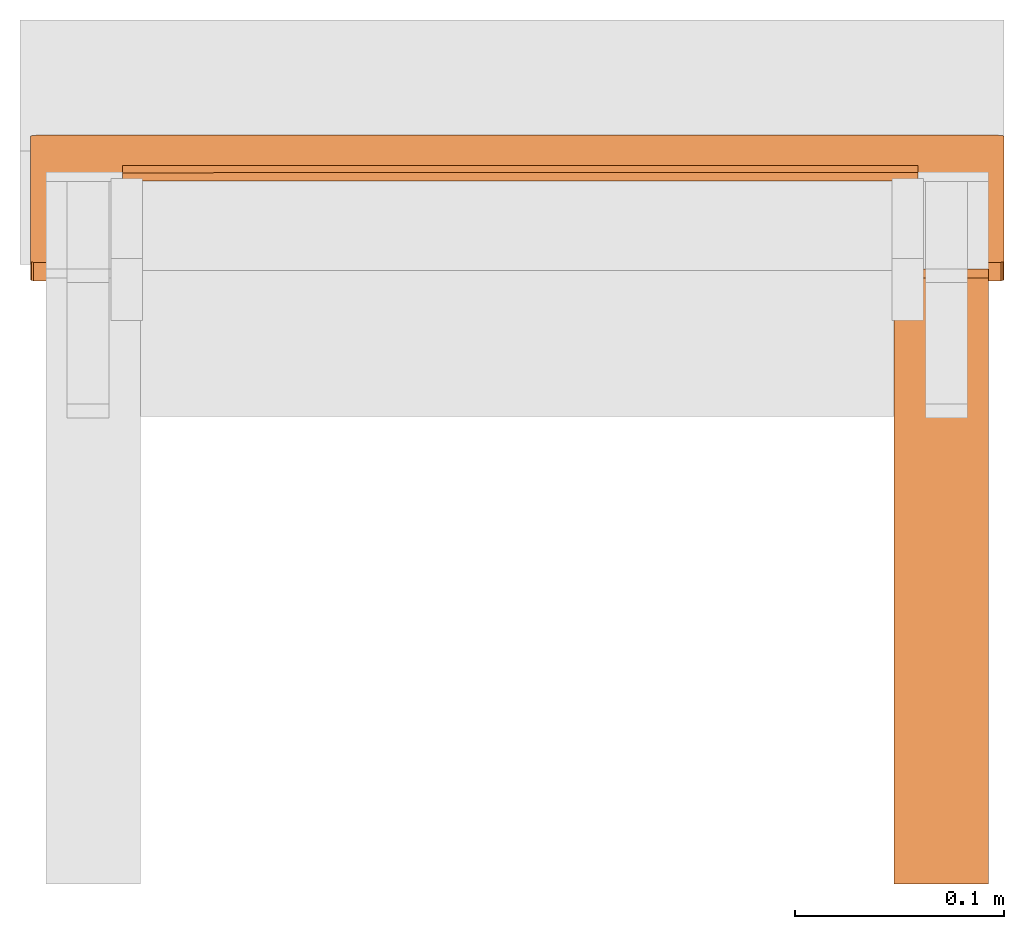
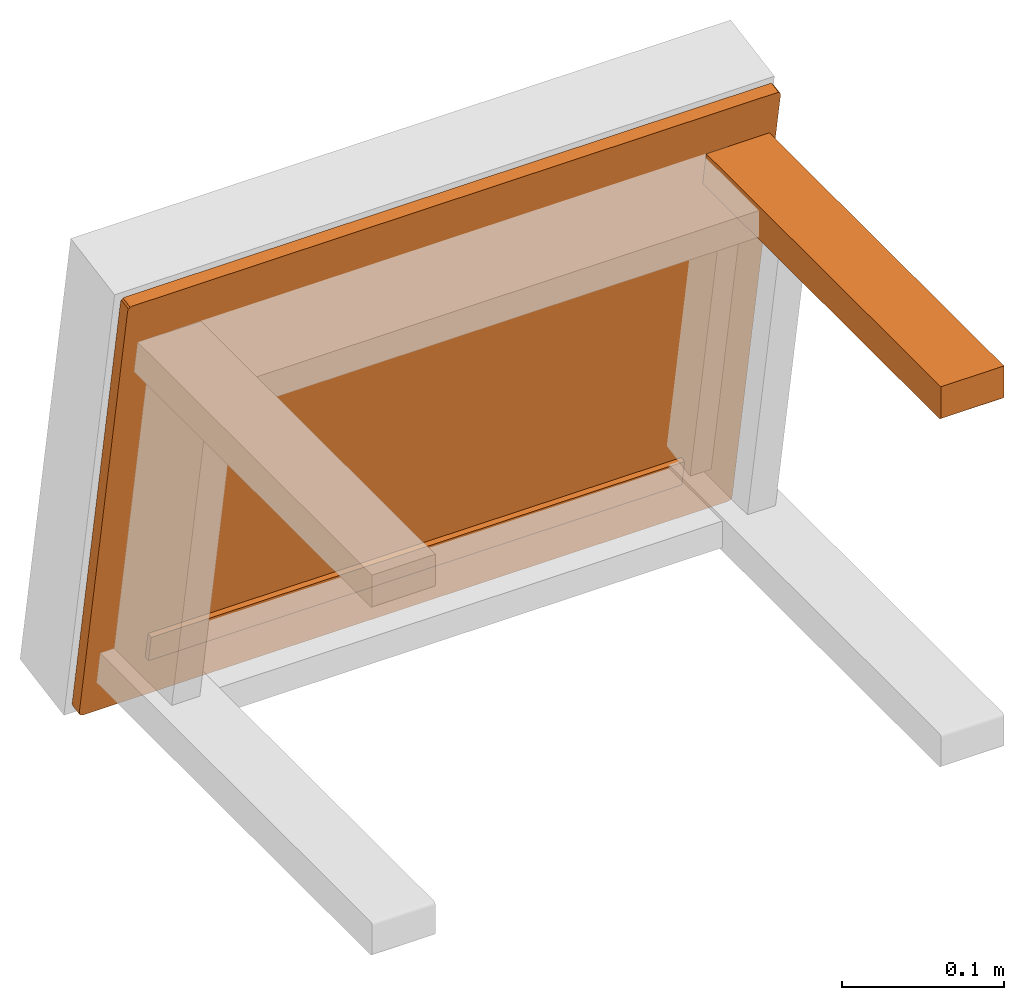
# One storey, part 3 of 5: 3 proxies, 1 element without a shape of its own.
"""IFC2X3 building model written with IfcOpenShell, lengths in metres."""

from ifc_helpers import new_model, si_unit, direction, origin_with_axes, place, context, project, spatial, faceted_brep, source, transform, mapped, element, aggregate, save


model = new_model("IFC2X3")

# Units and contexts
model_context = context("Model", 3, precision=1e-06, world=origin_with_axes(), true_north=direction((0.0, 1.0, 0.0)))
ifc_project = project(units=[si_unit("LENGTHUNIT", "METRE"), si_unit("AREAUNIT", "SQUARE_METRE"), si_unit("VOLUMEUNIT", "CUBIC_METRE")], contexts=[model_context])

# Site, building, storey
site_placement = place(None, origin_with_axes())
site = spatial("IfcSite", under=ifc_project, at=site_placement, CompositionType="ELEMENT")
building_placement = place(site_placement, origin_with_axes())
building = spatial("IfcBuilding", under=site, at=building_placement, Name="Default Building", CompositionType="ELEMENT")
storey_placement = place(building_placement, origin_with_axes())
storey = spatial("IfcBuildingStorey", under=building, at=storey_placement, Name="Default Storey", CompositionType="ELEMENT", Elevation=0.0)

# Assembly, proxies
assembly_placement = place(storey_placement, origin_with_axes())
assembly = element("IfcElementAssembly", 1, at=assembly_placement, inside=storey, Name="Pan H-68-037-A-REV reduced", ObjectType="Pan H-68-037-A-REV reduced", AssemblyPlace="NOTDEFINED", PredefinedType="NOTDEFINED")
shared_shape_1 = source(origin_with_axes(), model_context, "Body", "Brep", [
    faceted_brep([(-0.18850770592689514, 0.03473890945315361, -0.008519280701875687), (-0.18850770592689514, 0.038678139448165894, -0.007824688218533993), (0.1914917677640915, 0.034848056733608246, -0.009138284251093864), (0.1914917677640915, 0.034848056733608246, -0.009138284251093864), (-0.18850770592689514, 0.038678139448165894, -0.007824688218533993), (0.1914917677640915, 0.03878728672862053, -0.008443690836429596), (-0.18850770592689514, 0.038678139448165894, -0.007824688218533993), (-0.1884746253490448, 0.0352051816880703, 0.011871440336108208), (0.1914917677640915, 0.03878728672862053, -0.008443690836429596), (0.1914917677640915, 0.03878728672862053, -0.008443690836429596), (-0.1884746253490448, 0.0352051816880703, 0.011871440336108208), (0.19152484834194183, 0.03531432896852493, 0.01125243678689003), (-0.1884746253490448, 0.0352051816880703, 0.011871440336108208), (-0.1884746253490448, 0.031265951693058014, 0.011176847852766514), (0.19152484834194183, 0.03531432896852493, 0.01125243678689003), (0.19152484834194183, 0.03531432896852493, 0.01125243678689003), (-0.1884746253490448, 0.031265951693058014, 0.011176847852766514), (0.19152484834194183, 0.03137509897351265, 0.010557844303548336), (-0.1884746253490448, 0.031265951693058014, 0.011176847852766514), (-0.18850770592689514, 0.03473890945315361, -0.008519280701875687), (0.19152484834194183, 0.03137509897351265, 0.010557844303548336), (0.19152484834194183, 0.03137509897351265, 0.010557844303548336), (-0.18850770592689514, 0.03473890945315361, -0.008519280701875687), (0.1914917677640915, 0.034848056733608246, -0.009138284251093864), (-0.1884746253490448, 0.031265951693058014, 0.011176847852766514), (-0.1884746253490448, 0.0352051816880703, 0.011871440336108208), (-0.18850770592689514, 0.03473890945315361, -0.008519280701875687), (-0.18850770592689514, 0.03473890945315361, -0.008519280701875687), (-0.1884746253490448, 0.0352051816880703, 0.011871440336108208), (-0.18850770592689514, 0.038678139448165894, -0.007824688218533993), (0.19152484834194183, 0.03531432896852493, 0.01125243678689003), (0.19152484834194183, 0.03137509897351265, 0.010557844303548336), (0.1914917677640915, 0.03878728672862053, -0.008443690836429596), (0.1914917677640915, 0.03878728672862053, -0.008443690836429596), (0.19152484834194183, 0.03137509897351265, 0.010557844303548336), (0.1914917677640915, 0.034848056733608246, -0.009138284251093864)], [[[0, 1, 2]], [[3, 4, 5]], [[6, 7, 8]], [[9, 10, 11]], [[12, 13, 14]], [[15, 16, 17]], [[18, 19, 20]], [[21, 22, 23]], [[24, 25, 26]], [[27, 28, 29]], [[30, 31, 32]], [[33, 34, 35]]]),
])
proxy_1_placement = place(assembly_placement, origin_with_axes())
proxy_1 = element("IfcBuildingElementProxy", 2, at=proxy_1_placement, Name="19", ObjectType="19", CompositionType="ELEMENT", context=model_context, shape_type="MappedRepresentation", body=[
    mapped(shared_shape_1, transform((0.0, 0.0, 0.0), scale=1.0)),
])
shared_shape_2 = source(origin_with_axes(), model_context, "Body", "Brep", [
    faceted_brep([(-0.23250000178813934, 0.043760597705841064, -0.03780049830675125), (-0.23250000178813934, 0.052623867988586426, -0.03623766452074051), (-0.2320980727672577, 0.05288434028625488, -0.0377148762345314), (-0.23250000178813934, 0.043760597705841064, -0.03780049830675125), (-0.2320980727672577, 0.05288434028625488, -0.0377148762345314), (-0.2320980727672577, 0.04402107000350952, -0.039277710020542145), (-0.2320980727672577, 0.04402107000350952, -0.039277710020542145), (-0.2320980727672577, 0.05288434028625488, -0.0377148762345314), (-0.23100000619888306, 0.053075019270181656, -0.03879626840353012), (-0.2320980727672577, 0.04402107000350952, -0.039277710020542145), (-0.23100000619888306, 0.053075019270181656, -0.03879626840353012), (-0.23100000619888306, 0.044211748987436295, -0.04035910218954086), (-0.23100000619888306, 0.044211748987436295, -0.04035910218954086), (-0.23100000619888306, 0.053075019270181656, -0.03879626840353012), (-0.22949999570846558, 0.05314481258392334, -0.039192087948322296), (-0.23100000619888306, 0.044211748987436295, -0.04035910218954086), (-0.22949999570846558, 0.05314481258392334, -0.039192087948322296), (-0.22949999570846558, 0.04428154230117798, -0.04075492173433304), (-0.23250000178813934, 0.043760597705841064, -0.03780049830675125), (-0.23250000178813934, -0.0159743744879961, 0.3009733557701111), (-0.23250000178813934, 0.052623867988586426, -0.03623766452074051), (-0.23250000178813934, 0.052623867988586426, -0.03623766452074051), (-0.23250000178813934, -0.0159743744879961, 0.3009733557701111), (-0.23250000178813934, -0.007111104670912027, 0.3025361895561218), (-0.22949999570846558, -0.016495319083333015, 0.30392777919769287), (-0.22949999570846558, -0.007632049266248941, 0.3054906129837036), (-0.23100000619888306, -0.0075622559525072575, 0.30509480834007263), (-0.22949999570846558, -0.016495319083333015, 0.30392777919769287), (-0.23100000619888306, -0.0075622559525072575, 0.30509480834007263), (-0.23100000619888306, -0.01642552576959133, 0.3035319745540619), (-0.23100000619888306, -0.01642552576959133, 0.3035319745540619), (-0.23100000619888306, -0.0075622559525072575, 0.30509480834007263), (-0.2320980727672577, -0.007371576968580484, 0.3040134012699127), (-0.23100000619888306, -0.01642552576959133, 0.3035319745540619), (-0.2320980727672577, -0.007371576968580484, 0.3040134012699127), (-0.2320980727672577, -0.01623484678566456, 0.302450567483902), (-0.2320980727672577, -0.01623484678566456, 0.302450567483902), (-0.2320980727672577, -0.007371576968580484, 0.3040134012699127), (-0.23250000178813934, -0.007111104670912027, 0.3025361895561218), (-0.2320980727672577, -0.01623484678566456, 0.302450567483902), (-0.23250000178813934, -0.007111104670912027, 0.3025361895561218), (-0.23250000178813934, -0.0159743744879961, 0.3009733557701111), (-0.22949999570846558, -0.016495319083333015, 0.30392777919769287), (0.22949999570846558, -0.016495319083333015, 0.30392777919769287), (-0.22949999570846558, -0.007632049266248941, 0.3054906129837036), (-0.22949999570846558, -0.007632049266248941, 0.3054906129837036), (0.22949999570846558, -0.016495319083333015, 0.30392777919769287), (0.22949999570846558, -0.007632049266248941, 0.3054906129837036), (0.23250000178813934, -0.0159743744879961, 0.3009733557701111), (0.23250000178813934, -0.007111104670912027, 0.3025361895561218), (0.2320980727672577, -0.007371576968580484, 0.3040134012699127), (0.23250000178813934, -0.0159743744879961, 0.3009733557701111), (0.2320980727672577, -0.007371576968580484, 0.3040134012699127), (0.2320980727672577, -0.01623484678566456, 0.302450567483902), (0.2320980727672577, -0.01623484678566456, 0.302450567483902), (0.2320980727672577, -0.007371576968580484, 0.3040134012699127), (0.23100000619888306, -0.0075622559525072575, 0.30509480834007263), (0.2320980727672577, -0.01623484678566456, 0.302450567483902), (0.23100000619888306, -0.0075622559525072575, 0.30509480834007263), (0.23100000619888306, -0.01642552576959133, 0.3035319745540619), (0.23100000619888306, -0.01642552576959133, 0.3035319745540619), (0.23100000619888306, -0.0075622559525072575, 0.30509480834007263), (0.22949999570846558, -0.007632049266248941, 0.3054906129837036), (0.23100000619888306, -0.01642552576959133, 0.3035319745540619), (0.22949999570846558, -0.007632049266248941, 0.3054906129837036), (0.22949999570846558, -0.016495319083333015, 0.30392777919769287), (0.23250000178813934, -0.0159743744879961, 0.3009733557701111), (0.23250000178813934, 0.043760597705841064, -0.03780049830675125), (0.23250000178813934, -0.007111104670912027, 0.3025361895561218), (0.23250000178813934, -0.007111104670912027, 0.3025361895561218), (0.23250000178813934, 0.043760597705841064, -0.03780049830675125), (0.23250000178813934, 0.052623867988586426, -0.03623766452074051), (0.22949999570846558, 0.04428154230117798, -0.04075492173433304), (0.22949999570846558, 0.05314481258392334, -0.039192087948322296), (0.23100000619888306, 0.053075019270181656, -0.03879626840353012), (0.22949999570846558, 0.04428154230117798, -0.04075492173433304), (0.23100000619888306, 0.053075019270181656, -0.03879626840353012), (0.23100000619888306, 0.044211748987436295, -0.04035910218954086), (0.23100000619888306, 0.044211748987436295, -0.04035910218954086), (0.23100000619888306, 0.053075019270181656, -0.03879626840353012), (0.2320980727672577, 0.05288434028625488, -0.0377148762345314), (0.23100000619888306, 0.044211748987436295, -0.04035910218954086), (0.2320980727672577, 0.05288434028625488, -0.0377148762345314), (0.2320980727672577, 0.04402107000350952, -0.039277710020542145), (0.2320980727672577, 0.04402107000350952, -0.039277710020542145), (0.2320980727672577, 0.05288434028625488, -0.0377148762345314), (0.23250000178813934, 0.052623867988586426, -0.03623766452074051), (0.2320980727672577, 0.04402107000350952, -0.039277710020542145), (0.23250000178813934, 0.052623867988586426, -0.03623766452074051), (0.23250000178813934, 0.043760597705841064, -0.03780049830675125), (0.22949999570846558, 0.04428154230117798, -0.04075492173433304), (-0.22949999570846558, 0.04428154230117798, -0.04075492173433304), (0.22949999570846558, 0.05314481258392334, -0.039192087948322296), (0.22949999570846558, 0.05314481258392334, -0.039192087948322296), (-0.22949999570846558, 0.04428154230117798, -0.04075492173433304), (-0.22949999570846558, 0.05314481258392334, -0.039192087948322296), (0.22949999570846558, 0.04428154230117798, -0.04075492173433304), (0.22949999570846558, -0.016495319083333015, 0.30392777919769287), (-0.22949999570846558, 0.04428154230117798, -0.04075492173433304), (-0.22949999570846558, 0.04428154230117798, -0.04075492173433304), (0.22949999570846558, -0.016495319083333015, 0.30392777919769287), (-0.22949999570846558, -0.016495319083333015, 0.30392777919769287), (0.2320980727672577, -0.01623484678566456, 0.302450567483902), (0.23100000619888306, -0.01642552576959133, 0.3035319745540619), (0.23250000178813934, -0.0159743744879961, 0.3009733557701111), (0.23250000178813934, -0.0159743744879961, 0.3009733557701111), (0.23100000619888306, -0.01642552576959133, 0.3035319745540619), (0.22949999570846558, -0.016495319083333015, 0.30392777919769287), (0.23250000178813934, -0.0159743744879961, 0.3009733557701111), (0.22949999570846558, -0.016495319083333015, 0.30392777919769287), (0.23250000178813934, 0.043760597705841064, -0.03780049830675125), (0.23250000178813934, 0.043760597705841064, -0.03780049830675125), (0.22949999570846558, -0.016495319083333015, 0.30392777919769287), (0.22949999570846558, 0.04428154230117798, -0.04075492173433304), (0.23250000178813934, 0.043760597705841064, -0.03780049830675125), (0.22949999570846558, 0.04428154230117798, -0.04075492173433304), (0.2320980727672577, 0.04402107000350952, -0.039277710020542145), (0.2320980727672577, 0.04402107000350952, -0.039277710020542145), (0.22949999570846558, 0.04428154230117798, -0.04075492173433304), (0.23100000619888306, 0.044211748987436295, -0.04035910218954086), (-0.2320980727672577, 0.04402107000350952, -0.039277710020542145), (-0.23100000619888306, 0.044211748987436295, -0.04035910218954086), (-0.23250000178813934, 0.043760597705841064, -0.03780049830675125), (-0.23250000178813934, 0.043760597705841064, -0.03780049830675125), (-0.23100000619888306, 0.044211748987436295, -0.04035910218954086), (-0.22949999570846558, 0.04428154230117798, -0.04075492173433304), (-0.23250000178813934, 0.043760597705841064, -0.03780049830675125), (-0.22949999570846558, 0.04428154230117798, -0.04075492173433304), (-0.23250000178813934, -0.0159743744879961, 0.3009733557701111), (-0.23250000178813934, -0.0159743744879961, 0.3009733557701111), (-0.22949999570846558, 0.04428154230117798, -0.04075492173433304), (-0.22949999570846558, -0.016495319083333015, 0.30392777919769287), (-0.23250000178813934, -0.0159743744879961, 0.3009733557701111), (-0.22949999570846558, -0.016495319083333015, 0.30392777919769287), (-0.2320980727672577, -0.01623484678566456, 0.302450567483902), (-0.2320980727672577, -0.01623484678566456, 0.302450567483902), (-0.22949999570846558, -0.016495319083333015, 0.30392777919769287), (-0.23100000619888306, -0.01642552576959133, 0.3035319745540619), (0.23250000178813934, 0.052623867988586426, -0.03623766452074051), (-0.23250000178813934, 0.052623867988586426, -0.03623766452074051), (0.23250000178813934, -0.007111104670912027, 0.3025361895561218), (0.23250000178813934, -0.007111104670912027, 0.3025361895561218), (-0.23250000178813934, 0.052623867988586426, -0.03623766452074051), (-0.23250000178813934, -0.007111104670912027, 0.3025361895561218), (-0.23100000619888306, 0.053075019270181656, -0.03879626840353012), (-0.2320980727672577, 0.05288434028625488, -0.0377148762345314), (-0.22949999570846558, 0.05314481258392334, -0.039192087948322296), (-0.22949999570846558, 0.05314481258392334, -0.039192087948322296), (-0.2320980727672577, 0.05288434028625488, -0.0377148762345314), (-0.23250000178813934, 0.052623867988586426, -0.03623766452074051), (-0.22949999570846558, 0.05314481258392334, -0.039192087948322296), (-0.23250000178813934, 0.052623867988586426, -0.03623766452074051), (0.22949999570846558, 0.05314481258392334, -0.039192087948322296), (0.22949999570846558, 0.05314481258392334, -0.039192087948322296), (-0.23250000178813934, 0.052623867988586426, -0.03623766452074051), (0.23250000178813934, 0.052623867988586426, -0.03623766452074051), (0.22949999570846558, 0.05314481258392334, -0.039192087948322296), (0.23250000178813934, 0.052623867988586426, -0.03623766452074051), (0.23100000619888306, 0.053075019270181656, -0.03879626840353012), (0.23100000619888306, 0.053075019270181656, -0.03879626840353012), (0.23250000178813934, 0.052623867988586426, -0.03623766452074051), (0.2320980727672577, 0.05288434028625488, -0.0377148762345314), (0.23100000619888306, -0.0075622559525072575, 0.30509480834007263), (0.2320980727672577, -0.007371576968580484, 0.3040134012699127), (0.22949999570846558, -0.007632049266248941, 0.3054906129837036), (0.22949999570846558, -0.007632049266248941, 0.3054906129837036), (0.2320980727672577, -0.007371576968580484, 0.3040134012699127), (0.23250000178813934, -0.007111104670912027, 0.3025361895561218), (0.22949999570846558, -0.007632049266248941, 0.3054906129837036), (0.23250000178813934, -0.007111104670912027, 0.3025361895561218), (-0.22949999570846558, -0.007632049266248941, 0.3054906129837036), (-0.22949999570846558, -0.007632049266248941, 0.3054906129837036), (0.23250000178813934, -0.007111104670912027, 0.3025361895561218), (-0.23250000178813934, -0.007111104670912027, 0.3025361895561218), (-0.22949999570846558, -0.007632049266248941, 0.3054906129837036), (-0.23250000178813934, -0.007111104670912027, 0.3025361895561218), (-0.23100000619888306, -0.0075622559525072575, 0.30509480834007263), (-0.23100000619888306, -0.0075622559525072575, 0.30509480834007263), (-0.23250000178813934, -0.007111104670912027, 0.3025361895561218), (-0.2320980727672577, -0.007371576968580484, 0.3040134012699127)], [[[0, 1, 2]], [[3, 4, 5]], [[6, 7, 8]], [[9, 10, 11]], [[12, 13, 14]], [[15, 16, 17]], [[18, 19, 20]], [[21, 22, 23]], [[24, 25, 26]], [[27, 28, 29]], [[30, 31, 32]], [[33, 34, 35]], [[36, 37, 38]], [[39, 40, 41]], [[42, 43, 44]], [[45, 46, 47]], [[48, 49, 50]], [[51, 52, 53]], [[54, 55, 56]], [[57, 58, 59]], [[60, 61, 62]], [[63, 64, 65]], [[66, 67, 68]], [[69, 70, 71]], [[72, 73, 74]], [[75, 76, 77]], [[78, 79, 80]], [[81, 82, 83]], [[84, 85, 86]], [[87, 88, 89]], [[90, 91, 92]], [[93, 94, 95]], [[96, 97, 98]], [[99, 100, 101]], [[102, 103, 104]], [[105, 106, 107]], [[108, 109, 110]], [[111, 112, 113]], [[114, 115, 116]], [[117, 118, 119]], [[120, 121, 122]], [[123, 124, 125]], [[126, 127, 128]], [[129, 130, 131]], [[132, 133, 134]], [[135, 136, 137]], [[138, 139, 140]], [[141, 142, 143]], [[144, 145, 146]], [[147, 148, 149]], [[150, 151, 152]], [[153, 154, 155]], [[156, 157, 158]], [[159, 160, 161]], [[162, 163, 164]], [[165, 166, 167]], [[168, 169, 170]], [[171, 172, 173]], [[174, 175, 176]], [[177, 178, 179]]]),
])
proxy_2_placement = place(assembly_placement, origin_with_axes())
proxy_2 = element("IfcBuildingElementProxy", 3, at=proxy_2_placement, Name="20", ObjectType="20", CompositionType="ELEMENT", context=model_context, shape_type="MappedRepresentation", body=[
    mapped(shared_shape_2, transform((0.0, 0.0, 0.0), scale=1.0)),
])
shared_shape_3 = source(origin_with_axes(), model_context, "Body", "Brep", [
    faceted_brep([(0.22499999403953552, -0.09570664912462234, 0.24950098991394043), (0.22499999403953552, -0.30253592133522034, 0.24950098991394043), (0.18000000715255737, -0.09570664912462234, 0.24950098991394043), (0.18000000715255737, -0.09570664912462234, 0.24950098991394043), (0.22499999403953552, -0.30253592133522034, 0.24950098991394043), (0.18000000715255737, -0.30253592133522034, 0.24950098991394043), (0.22499999403953552, -0.3045358955860138, 0.2515009939670563), (0.18000000715255737, -0.3045358955860138, 0.2515009939670563), (0.18000000715255737, -0.3044677674770355, 0.2509833574295044), (0.22499999403953552, -0.3045358955860138, 0.2515009939670563), (0.18000000715255737, -0.3044677674770355, 0.2509833574295044), (0.22499999403953552, -0.3044677674770355, 0.2509833574295044), (0.22499999403953552, -0.3044677674770355, 0.2509833574295044), (0.18000000715255737, -0.3044677674770355, 0.2509833574295044), (0.18000000715255737, -0.3042679727077484, 0.25050097703933716), (0.22499999403953552, -0.3044677674770355, 0.2509833574295044), (0.18000000715255737, -0.3042679727077484, 0.25050097703933716), (0.22499999403953552, -0.3042679727077484, 0.25050097703933716), (0.22499999403953552, -0.3042679727077484, 0.25050097703933716), (0.18000000715255737, -0.3042679727077484, 0.25050097703933716), (0.18000000715255737, -0.30395013093948364, 0.25008678436279297), (0.22499999403953552, -0.3042679727077484, 0.25050097703933716), (0.18000000715255737, -0.30395013093948364, 0.25008678436279297), (0.22499999403953552, -0.30395013093948364, 0.25008678436279297), (0.22499999403953552, -0.30395013093948364, 0.25008678436279297), (0.18000000715255737, -0.30395013093948364, 0.25008678436279297), (0.18000000715255737, -0.30353590846061707, 0.2497689425945282), (0.22499999403953552, -0.30395013093948364, 0.25008678436279297), (0.18000000715255737, -0.30353590846061707, 0.2497689425945282), (0.22499999403953552, -0.30353590846061707, 0.2497689425945282), (0.22499999403953552, -0.30353590846061707, 0.2497689425945282), (0.18000000715255737, -0.30353590846061707, 0.2497689425945282), (0.18000000715255737, -0.3030535578727722, 0.2495691329240799), (0.22499999403953552, -0.30353590846061707, 0.2497689425945282), (0.18000000715255737, -0.3030535578727722, 0.2495691329240799), (0.22499999403953552, -0.3030535578727722, 0.2495691329240799), (0.22499999403953552, -0.3030535578727722, 0.2495691329240799), (0.18000000715255737, -0.3030535578727722, 0.2495691329240799), (0.18000000715255737, -0.30253592133522034, 0.24950098991394043), (0.22499999403953552, -0.3030535578727722, 0.2495691329240799), (0.18000000715255737, -0.30253592133522034, 0.24950098991394043), (0.22499999403953552, -0.30253592133522034, 0.24950098991394043), (0.22499999403953552, -0.3045358955860138, 0.2515009939670563), (0.22499999403953552, -0.3045358955860138, 0.2745009958744049), (0.18000000715255737, -0.3045358955860138, 0.2515009939670563), (0.18000000715255737, -0.3045358955860138, 0.2515009939670563), (0.22499999403953552, -0.3045358955860138, 0.2745009958744049), (0.18000000715255737, -0.3045358955860138, 0.2745009958744049), (0.22499999403953552, -0.3045358955860138, 0.2745009958744049), (0.22499999403953552, -0.09570664912462234, 0.2745009958744049), (0.18000000715255737, -0.3045358955860138, 0.2745009958744049), (0.18000000715255737, -0.3045358955860138, 0.2745009958744049), (0.22499999403953552, -0.09570664912462234, 0.2745009958744049), (0.18000000715255737, -0.09570664912462234, 0.2745009958744049), (0.22499999403953552, -0.09570664912462234, 0.2745009958744049), (0.22499999403953552, -0.015157913789153099, 0.2745009958744049), (0.18000000715255737, -0.09570664912462234, 0.2745009958744049), (0.18000000715255737, -0.09570664912462234, 0.2745009958744049), (0.22499999403953552, -0.015157913789153099, 0.2745009958744049), (0.18000000715255737, -0.015157913789153099, 0.2745009958744049), (0.22499999403953552, -0.015157913789153099, 0.2745009958744049), (0.22499999403953552, -0.014805259183049202, 0.27250099182128906), (0.18000000715255737, -0.015157913789153099, 0.2745009958744049), (0.18000000715255737, -0.015157913789153099, 0.2745009958744049), (0.22499999403953552, -0.014805259183049202, 0.27250099182128906), (0.18000000715255737, -0.014805259183049202, 0.27250099182128906), (0.22499999403953552, -0.014805259183049202, 0.27250099182128906), (0.22499999403953552, -0.011102392338216305, 0.2515009939670563), (0.18000000715255737, -0.014805259183049202, 0.27250099182128906), (0.18000000715255737, -0.014805259183049202, 0.27250099182128906), (0.22499999403953552, -0.011102392338216305, 0.2515009939670563), (0.18000000715255737, -0.011102392338216305, 0.2515009939670563), (0.22499999403953552, -0.011102392338216305, 0.2515009939670563), (0.22499999403953552, -0.010749738663434982, 0.24950098991394043), (0.18000000715255737, -0.011102392338216305, 0.2515009939670563), (0.18000000715255737, -0.011102392338216305, 0.2515009939670563), (0.22499999403953552, -0.010749738663434982, 0.24950098991394043), (0.18000000715255737, -0.010749738663434982, 0.24950098991394043), (0.22499999403953552, -0.010749738663434982, 0.24950098991394043), (0.22499999403953552, -0.09570664912462234, 0.24950098991394043), (0.18000000715255737, -0.010749738663434982, 0.24950098991394043), (0.18000000715255737, -0.010749738663434982, 0.24950098991394043), (0.22499999403953552, -0.09570664912462234, 0.24950098991394043), (0.18000000715255737, -0.09570664912462234, 0.24950098991394043), (0.22499999403953552, -0.010749738663434982, 0.24950098991394043), (0.22499999403953552, -0.011102392338216305, 0.2515009939670563), (0.22499999403953552, -0.09570664912462234, 0.24950098991394043), (0.22499999403953552, -0.09570664912462234, 0.24950098991394043), (0.22499999403953552, -0.011102392338216305, 0.2515009939670563), (0.22499999403953552, -0.014805259183049202, 0.27250099182128906), (0.22499999403953552, -0.09570664912462234, 0.24950098991394043), (0.22499999403953552, -0.014805259183049202, 0.27250099182128906), (0.22499999403953552, -0.30253592133522034, 0.24950098991394043), (0.22499999403953552, -0.014805259183049202, 0.27250099182128906), (0.22499999403953552, -0.015157913789153099, 0.2745009958744049), (0.22499999403953552, -0.09570664912462234, 0.2745009958744049), (0.22499999403953552, -0.09570664912462234, 0.2745009958744049), (0.22499999403953552, -0.3045358955860138, 0.2745009958744049), (0.22499999403953552, -0.3045358955860138, 0.2515009939670563), (0.22499999403953552, -0.014805259183049202, 0.27250099182128906), (0.22499999403953552, -0.09570664912462234, 0.2745009958744049), (0.22499999403953552, -0.30253592133522034, 0.24950098991394043), (0.22499999403953552, -0.30253592133522034, 0.24950098991394043), (0.22499999403953552, -0.09570664912462234, 0.2745009958744049), (0.22499999403953552, -0.3045358955860138, 0.2515009939670563), (0.22499999403953552, -0.30253592133522034, 0.24950098991394043), (0.22499999403953552, -0.3045358955860138, 0.2515009939670563), (0.22499999403953552, -0.3030535578727722, 0.2495691329240799), (0.22499999403953552, -0.3044677674770355, 0.2509833574295044), (0.22499999403953552, -0.3042679727077484, 0.25050097703933716), (0.22499999403953552, -0.30395013093948364, 0.25008678436279297), (0.22499999403953552, -0.3044677674770355, 0.2509833574295044), (0.22499999403953552, -0.30395013093948364, 0.25008678436279297), (0.22499999403953552, -0.3045358955860138, 0.2515009939670563), (0.22499999403953552, -0.3045358955860138, 0.2515009939670563), (0.22499999403953552, -0.30395013093948364, 0.25008678436279297), (0.22499999403953552, -0.30353590846061707, 0.2497689425945282), (0.22499999403953552, -0.3045358955860138, 0.2515009939670563), (0.22499999403953552, -0.30353590846061707, 0.2497689425945282), (0.22499999403953552, -0.3030535578727722, 0.2495691329240799), (0.18000000715255737, -0.3045358955860138, 0.2515009939670563), (0.18000000715255737, -0.3045358955860138, 0.2745009958744049), (0.18000000715255737, -0.09570664912462234, 0.2745009958744049), (0.18000000715255737, -0.30253592133522034, 0.24950098991394043), (0.18000000715255737, -0.014805259183049202, 0.27250099182128906), (0.18000000715255737, -0.09570664912462234, 0.24950098991394043), (0.18000000715255737, -0.09570664912462234, 0.24950098991394043), (0.18000000715255737, -0.014805259183049202, 0.27250099182128906), (0.18000000715255737, -0.011102392338216305, 0.2515009939670563), (0.18000000715255737, -0.09570664912462234, 0.24950098991394043), (0.18000000715255737, -0.011102392338216305, 0.2515009939670563), (0.18000000715255737, -0.010749738663434982, 0.24950098991394043), (0.18000000715255737, -0.30353590846061707, 0.2497689425945282), (0.18000000715255737, -0.30395013093948364, 0.25008678436279297), (0.18000000715255737, -0.3045358955860138, 0.2515009939670563), (0.18000000715255737, -0.3045358955860138, 0.2515009939670563), (0.18000000715255737, -0.30395013093948364, 0.25008678436279297), (0.18000000715255737, -0.3042679727077484, 0.25050097703933716), (0.18000000715255737, -0.3045358955860138, 0.2515009939670563), (0.18000000715255737, -0.3042679727077484, 0.25050097703933716), (0.18000000715255737, -0.3044677674770355, 0.2509833574295044), (0.18000000715255737, -0.015157913789153099, 0.2745009958744049), (0.18000000715255737, -0.014805259183049202, 0.27250099182128906), (0.18000000715255737, -0.09570664912462234, 0.2745009958744049), (0.18000000715255737, -0.09570664912462234, 0.2745009958744049), (0.18000000715255737, -0.014805259183049202, 0.27250099182128906), (0.18000000715255737, -0.30253592133522034, 0.24950098991394043), (0.18000000715255737, -0.09570664912462234, 0.2745009958744049), (0.18000000715255737, -0.30253592133522034, 0.24950098991394043), (0.18000000715255737, -0.3045358955860138, 0.2515009939670563), (0.18000000715255737, -0.3045358955860138, 0.2515009939670563), (0.18000000715255737, -0.30253592133522034, 0.24950098991394043), (0.18000000715255737, -0.3030535578727722, 0.2495691329240799), (0.18000000715255737, -0.3045358955860138, 0.2515009939670563), (0.18000000715255737, -0.3030535578727722, 0.2495691329240799), (0.18000000715255737, -0.30353590846061707, 0.2497689425945282)], [[[0, 1, 2]], [[3, 4, 5]], [[6, 7, 8]], [[9, 10, 11]], [[12, 13, 14]], [[15, 16, 17]], [[18, 19, 20]], [[21, 22, 23]], [[24, 25, 26]], [[27, 28, 29]], [[30, 31, 32]], [[33, 34, 35]], [[36, 37, 38]], [[39, 40, 41]], [[42, 43, 44]], [[45, 46, 47]], [[48, 49, 50]], [[51, 52, 53]], [[54, 55, 56]], [[57, 58, 59]], [[60, 61, 62]], [[63, 64, 65]], [[66, 67, 68]], [[69, 70, 71]], [[72, 73, 74]], [[75, 76, 77]], [[78, 79, 80]], [[81, 82, 83]], [[84, 85, 86]], [[87, 88, 89]], [[90, 91, 92]], [[93, 94, 95]], [[96, 97, 98]], [[99, 100, 101]], [[102, 103, 104]], [[105, 106, 107]], [[108, 109, 110]], [[111, 112, 113]], [[114, 115, 116]], [[117, 118, 119]], [[120, 121, 122]], [[123, 124, 125]], [[126, 127, 128]], [[129, 130, 131]], [[132, 133, 134]], [[135, 136, 137]], [[138, 139, 140]], [[141, 142, 143]], [[144, 145, 146]], [[147, 148, 149]], [[150, 151, 152]], [[153, 154, 155]]]),
])
proxy_3_placement = place(assembly_placement, origin_with_axes())
proxy_3 = element("IfcBuildingElementProxy", 4, at=proxy_3_placement, Name="23", ObjectType="23", CompositionType="ELEMENT", context=model_context, shape_type="MappedRepresentation", body=[
    mapped(shared_shape_3, transform((0.0, 0.0, 0.0), scale=1.0)),
])
aggregate(assembly, [proxy_1, proxy_2, proxy_3])

save(model, "model.ifc")
